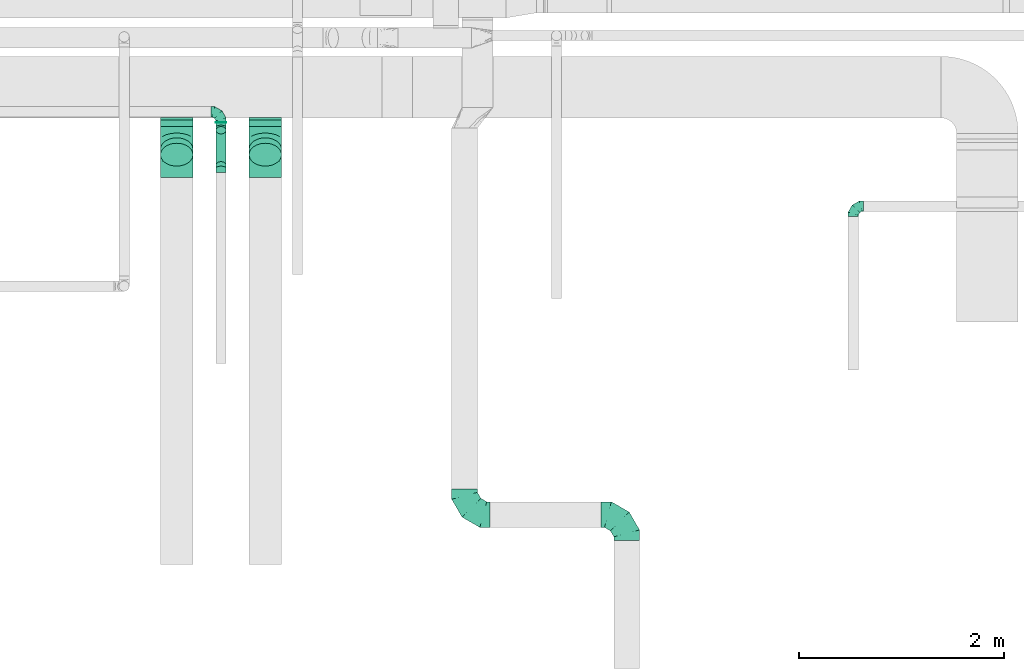
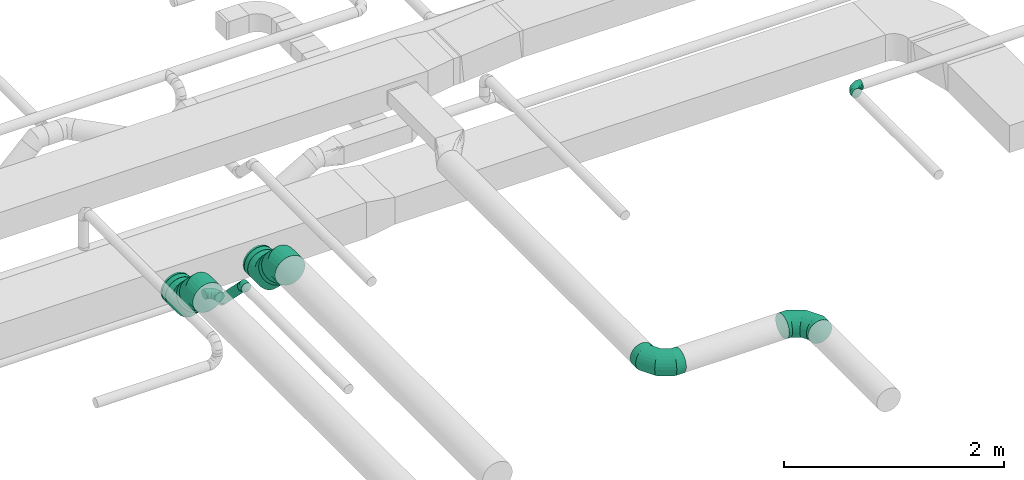
# One storey, part 37 of 60: 12 flow fittings, 6 flow segments.
"""IFC2X3 building model written with IfcOpenShell, lengths in millimetres."""

from ifc_helpers import new_model, entity, si_unit, converted_unit, derived_unit, direction, frame, origin, origin_2d_with_axis, place, context, subcontext, project, spatial, circle, extrude, faceted_brep, source, transform, mapped, material, type_object, type_shapes, element, save


model = new_model("IFC2X3")

# Units and contexts
model_context = context("Model", 3, precision=0.01, world=origin(), true_north=direction((6.12303176911189e-17, 1.0)))
body_context = subcontext(model_context, "Body", "Model", "MODEL_VIEW")
ifc_project = project(units=[si_unit("LENGTHUNIT", "METRE", prefix="MILLI"), si_unit("AREAUNIT", "SQUARE_METRE"), si_unit("VOLUMEUNIT", "CUBIC_METRE"), converted_unit("PLANEANGLEUNIT", "DEGREE", entity("IfcRatioMeasure", 0.0174532925199433), si_unit("PLANEANGLEUNIT", "RADIAN"), dimensions=[0, 0, 0, 0, 0, 0, 0]), si_unit("MASSUNIT", "GRAM", prefix="KILO"), derived_unit("MASSDENSITYUNIT", [(si_unit("MASSUNIT", "GRAM", prefix="KILO"), 1), (si_unit("LENGTHUNIT", "METRE"), -3)]), derived_unit("MOMENTOFINERTIAUNIT", [(si_unit("LENGTHUNIT", "METRE"), 4)]), si_unit("TIMEUNIT", "SECOND"), si_unit("FREQUENCYUNIT", "HERTZ"), si_unit("THERMODYNAMICTEMPERATUREUNIT", "DEGREE_CELSIUS"), derived_unit("THERMALTRANSMITTANCEUNIT", [(si_unit("MASSUNIT", "GRAM", prefix="KILO"), 1), (si_unit("THERMODYNAMICTEMPERATUREUNIT", "KELVIN"), -1), (si_unit("TIMEUNIT", "SECOND"), -3)]), derived_unit("VOLUMETRICFLOWRATEUNIT", [(si_unit("LENGTHUNIT", "METRE"), 3), (si_unit("TIMEUNIT", "SECOND"), -1)]), derived_unit("MASSFLOWRATEUNIT", [(si_unit("MASSUNIT", "GRAM", prefix="KILO"), 1), (si_unit("TIMEUNIT", "SECOND"), -1)]), derived_unit("ROTATIONALFREQUENCYUNIT", [(si_unit("TIMEUNIT", "SECOND"), -1)]), si_unit("ELECTRICCURRENTUNIT", "AMPERE"), si_unit("ELECTRICVOLTAGEUNIT", "VOLT"), si_unit("POWERUNIT", "WATT"), si_unit("FORCEUNIT", "NEWTON", prefix="KILO"), si_unit("ILLUMINANCEUNIT", "LUX"), si_unit("LUMINOUSFLUXUNIT", "LUMEN"), si_unit("LUMINOUSINTENSITYUNIT", "CANDELA"), derived_unit("USERDEFINED", [(si_unit("MASSUNIT", "GRAM", prefix="KILO"), -1), (si_unit("LENGTHUNIT", "METRE"), -2), (si_unit("TIMEUNIT", "SECOND"), 3), (si_unit("LUMINOUSFLUXUNIT", "LUMEN"), 1)]), derived_unit("LINEARVELOCITYUNIT", [(si_unit("LENGTHUNIT", "METRE"), 1), (si_unit("TIMEUNIT", "SECOND"), -1)]), si_unit("PRESSUREUNIT", "PASCAL"), derived_unit("USERDEFINED", [(si_unit("LENGTHUNIT", "METRE"), -2), (si_unit("MASSUNIT", "GRAM", prefix="KILO"), 1), (si_unit("TIMEUNIT", "SECOND"), -2)]), derived_unit("LINEARFORCEUNIT", [(si_unit("MASSUNIT", "GRAM", prefix="KILO"), 1), (si_unit("LENGTHUNIT", "METRE"), 1), (si_unit("TIMEUNIT", "SECOND"), -2), (si_unit("LENGTHUNIT", "METRE"), -1)]), derived_unit("PLANARFORCEUNIT", [(si_unit("MASSUNIT", "GRAM", prefix="KILO"), 1), (si_unit("LENGTHUNIT", "METRE"), 1), (si_unit("TIMEUNIT", "SECOND"), -2), (si_unit("LENGTHUNIT", "METRE"), -2)])], contexts=[model_context])

# Site, building, storey
site_placement = place(None, origin())
site = spatial("IfcSite", under=ifc_project, at=site_placement, CompositionType="ELEMENT")
building_placement = place(site_placement, origin())
building = spatial("IfcBuilding", under=site, at=building_placement, CompositionType="ELEMENT")
storey_placement = place(building_placement, frame((0.0, 0.0, 19800.0)))
storey = spatial("IfcBuildingStorey", under=building, at=storey_placement, CompositionType="ELEMENT", Elevation=19800.0)

# Flow segments
duct_segment_type = type_object("IfcDuctSegmentType", PredefinedType="NOTDEFINED")
flow_segment_1_placement = place(storey_placement, frame((57918.81, 8040.52, 2748.4)))
element("IfcFlowSegment", 1, at=flow_segment_1_placement, inside=storey, type_object=duct_segment_type, context=body_context, shape_type="SweptSolid", body=[
    extrude(circle(Radius=50.0, at=origin_2d_with_axis()), frame((51.6, 0.0, 51.6), z_axis=(0.0, 1.0, 0.0), x_axis=(-1.0, 0.0, 0.0)), (0.0, 0.0, 1.0), 8.5786437627044),
])
flow_segment_2_placement = place(storey_placement, frame((57918.81, 7591.43, 2792.34)))
element("IfcFlowSegment", 2, at=flow_segment_2_placement, inside=storey, type_object=duct_segment_type, context=body_context, shape_type="SweptSolid", body=[
    extrude(circle(Radius=50.0, at=origin_2d_with_axis()), frame((51.6, 378.37, 36.95), z_axis=(0.0, -0.707106781186546, 0.707106781186549), x_axis=(-1.0, 0.0, 0.0)), (0.0, 0.0, 1.0), 482.84271247463),
])
flow_segment_3_placement = place(storey_placement, frame((58242.69, 7618.75, 3011.8)))
element("IfcFlowSegment", 3, at=flow_segment_3_placement, inside=storey, type_object=duct_segment_type, context=body_context, shape_type="SweptSolid", body=[
    extrude(circle(Radius=157.5, at=origin_2d_with_axis()), frame((159.1, 165.94, 112.96), z_axis=(0.0, -0.707106781186428, 0.707106781186667), x_axis=(1.0, 0.0, 0.0)), (0.0, 0.0, 1.0), 74.9211767686856),
])
flow_segment_4_placement = place(storey_placement, frame((58242.69, 8007.48, 2873.36)))
element("IfcFlowSegment", 4, at=flow_segment_4_placement, inside=storey, type_object=duct_segment_type, context=body_context, shape_type="SweptSolid", body=[
    extrude(circle(Radius=157.5, at=origin_2d_with_axis()), frame((159.1, 0.0, 159.1), z_axis=(0.0, 1.0, 0.0), x_axis=(1.0, 0.0, 0.0)), (0.0, 0.0, 1.0), 61.9743878930634),
])
flow_segment_5_placement = place(storey_placement, frame((57379.82, 7618.75, 3011.8)))
element("IfcFlowSegment", 5, at=flow_segment_5_placement, inside=storey, type_object=duct_segment_type, context=body_context, shape_type="SweptSolid", body=[
    extrude(circle(Radius=157.5, at=origin_2d_with_axis()), frame((159.1, 112.96, 165.94), z_axis=(0.0, 0.707106781186554, -0.707106781186541), x_axis=(1.0, 0.0, 0.0)), (0.0, 0.0, 1.0), 74.9211767686642),
])
flow_segment_6_placement = place(storey_placement, frame((57379.82, 8007.48, 2873.36)))
element("IfcFlowSegment", 6, at=flow_segment_6_placement, inside=storey, type_object=duct_segment_type, context=body_context, shape_type="SweptSolid", body=[
    extrude(circle(Radius=157.5, at=origin_2d_with_axis()), frame((159.1, 0.0, 159.1), z_axis=(0.0, 1.0, 0.0), x_axis=(1.0, 0.0, 0.0)), (0.0, 0.0, 1.0), 61.97438789311),
])

# Flow fittings
ifc_material = material()
duct_fitting_type_1 = type_object("IfcDuctFittingType", PredefinedType="NOTDEFINED", material=ifc_material)
shared_shape_1 = source(origin(), body_context, "Body", "Brep", [
    faceted_brep([(-100.0, 0.0, -50.0), (-100.0, -12.94, -48.3), (-100.0, -25.0, -43.3), (-100.0, -35.36, -35.36), (-100.0, -43.3, -25.0), (-100.0, -48.3, -12.94), (-100.0, -50.0, 0.0), (-100.0, -48.3, 12.94), (-100.0, -43.3, 25.0), (-100.0, -35.36, 35.36), (-100.0, -25.0, 43.3), (-100.0, -12.94, 48.3), (-100.0, 0.0, 50.0), (-100.0, 12.94, 48.3), (-100.0, 25.0, 43.3), (-100.0, 35.36, 35.36), (-100.0, 43.3, 25.0), (-100.0, 48.3, 12.94), (-100.0, 50.0, 0.0), (-100.0, 48.3, -12.94), (-100.0, 43.3, -25.0), (-100.0, 35.36, -35.36), (-100.0, 25.0, -43.3), (-100.0, 12.94, -48.3), (-76.67, 12.94, 48.3), (-79.9, 25.0, 43.3), (-73.21, 0.0, 50.0), (-82.68, 35.36, 35.36), (-86.15, 48.3, 12.94), (-86.6, 50.0, 0.0), (-84.81, 43.3, 25.0), (-84.81, 43.3, -25.0), (-82.68, 35.36, -35.36), (-86.15, 48.3, -12.94), (-76.67, 12.94, -48.3), (-73.21, 0.0, -50.0), (-79.9, 25.0, -43.3), (-69.74, -12.94, -48.3), (-66.51, -25.0, -43.3), (-63.73, -35.36, -35.36), (-61.6, -43.3, -25.0), (-60.26, -48.3, -12.94), (-59.81, -50.0, 0.0), (-60.26, -48.3, 12.94), (-61.6, -43.3, 25.0), (-63.73, -35.36, 35.36), (-66.51, -25.0, 43.3), (-69.74, -12.94, 48.3), (-36.27, 36.27, 48.3), (-45.1, 45.1, 43.3), (-26.79, 26.79, 50.0), (-52.68, 52.68, 35.36), (-58.49, 58.49, 25.0), (-62.15, 62.15, 12.94), (-63.4, 63.4, 0.0), (-62.15, 62.15, -12.94), (-58.49, 58.49, -25.0), (-52.68, 52.68, -35.36), (-36.27, 36.27, -48.3), (-26.79, 26.79, -50.0), (-45.1, 45.1, -43.3), (-17.32, 17.32, -48.3), (-8.49, 8.49, -43.3), (-0.91, 0.91, -35.36), (4.9, -4.9, -25.0), (8.56, -8.56, -12.94), (9.81, -9.81, 0.0), (8.56, -8.56, 12.94), (4.9, -4.9, 25.0), (-0.91, 0.91, 35.36), (-8.49, 8.49, 43.3), (-17.32, 17.32, 48.3), (-12.94, 76.67, 48.3), (-25.0, 79.9, 43.3), (0.0, 73.21, 50.0), (-35.36, 82.68, 35.36), (-43.3, 84.81, 25.0), (-48.3, 86.15, 12.94), (-50.0, 86.6, 0.0), (-48.3, 86.15, -12.94), (-43.3, 84.81, -25.0), (-35.36, 82.68, -35.36), (-12.94, 76.67, -48.3), (0.0, 73.21, -50.0), (-25.0, 79.9, -43.3), (12.94, 69.74, -48.3), (25.0, 66.51, -43.3), (35.36, 63.73, -35.36), (43.3, 61.6, -25.0), (48.3, 60.26, -12.94), (50.0, 59.81, 0.0), (48.3, 60.26, 12.94), (43.3, 61.6, 25.0), (35.36, 63.73, 35.36), (25.0, 66.51, 43.3), (12.94, 69.74, 48.3), (-12.94, 100.0, -48.3), (-25.0, 100.0, -43.3), (-35.36, 100.0, -35.36), (-43.3, 100.0, -25.0), (-48.3, 100.0, -12.94), (-50.0, 100.0, 0.0), (-48.3, 100.0, 12.94), (-43.3, 100.0, 25.0), (-35.36, 100.0, 35.36), (-25.0, 100.0, 43.3), (-12.94, 100.0, 48.3), (0.0, 100.0, 50.0), (12.94, 100.0, 48.3), (25.0, 100.0, 43.3), (35.36, 100.0, 35.36), (43.3, 100.0, 25.0), (48.3, 100.0, 12.94), (50.0, 100.0, 0.0), (48.3, 100.0, -12.94), (43.3, 100.0, -25.0), (35.36, 100.0, -35.36), (25.0, 100.0, -43.3), (12.94, 100.0, -48.3), (0.0, 100.0, -50.0)], [[[0, 1, 2, 3, 4, 5, 6, 7, 8, 9, 10, 11, 12, 13, 14, 15, 16, 17, 18, 19, 20, 21, 22, 23]], [[24, 25, 14, 13]], [[26, 24, 13, 12]], [[14, 25, 27, 15]], [[28, 29, 18, 17]], [[30, 28, 17, 16]], [[15, 27, 30, 16]], [[20, 31, 32, 21]], [[33, 31, 20, 19]], [[18, 29, 33, 19]], [[34, 35, 0, 23]], [[36, 34, 23, 22]], [[32, 36, 22, 21]], [[2, 1, 37, 38]], [[3, 2, 38, 39]], [[0, 35, 37, 1]], [[5, 4, 40, 41]], [[6, 5, 41, 42]], [[3, 39, 40, 4]], [[6, 42, 43, 7]], [[7, 43, 44, 8]], [[8, 44, 45, 9]], [[10, 46, 47, 11]], [[11, 47, 26, 12]], [[10, 9, 45, 46]], [[48, 49, 25, 24]], [[50, 48, 24, 26]], [[27, 25, 49, 51]], [[52, 53, 28, 30]], [[51, 52, 30, 27]], [[29, 28, 53, 54]], [[55, 56, 31, 33]], [[54, 55, 33, 29]], [[57, 32, 31, 56]], [[58, 59, 35, 34]], [[60, 58, 34, 36]], [[57, 60, 36, 32]], [[37, 35, 59, 61]], [[38, 37, 61, 62]], [[39, 38, 62, 63]], [[41, 40, 64, 65]], [[42, 41, 65, 66]], [[63, 64, 40, 39]], [[43, 42, 66, 67]], [[44, 43, 67, 68]], [[68, 69, 45, 44]], [[46, 45, 69, 70]], [[47, 46, 70, 71]], [[26, 47, 71, 50]], [[72, 73, 49, 48]], [[74, 72, 48, 50]], [[51, 49, 73, 75]], [[76, 77, 53, 52]], [[75, 76, 52, 51]], [[54, 53, 77, 78]], [[79, 80, 56, 55]], [[78, 79, 55, 54]], [[81, 57, 56, 80]], [[82, 83, 59, 58]], [[84, 82, 58, 60]], [[81, 84, 60, 57]], [[61, 59, 83, 85]], [[62, 61, 85, 86]], [[63, 62, 86, 87]], [[65, 64, 88, 89]], [[66, 65, 89, 90]], [[87, 88, 64, 63]], [[67, 66, 90, 91]], [[68, 67, 91, 92]], [[92, 93, 69, 68]], [[70, 69, 93, 94]], [[71, 70, 94, 95]], [[50, 71, 95, 74]], [[96, 97, 98, 99, 100, 101, 102, 103, 104, 105, 106, 107, 108, 109, 110, 111, 112, 113, 114, 115, 116, 117, 118, 119]], [[72, 74, 107, 106]], [[73, 72, 106, 105]], [[75, 73, 105, 104]], [[77, 76, 103, 102]], [[78, 77, 102, 101]], [[75, 104, 103, 76]], [[78, 101, 100, 79]], [[79, 100, 99, 80]], [[80, 99, 98, 81]], [[96, 119, 83, 82]], [[97, 96, 82, 84]], [[84, 81, 98, 97]], [[83, 119, 118, 85]], [[85, 118, 117, 86]], [[86, 117, 116, 87]], [[88, 115, 114, 89]], [[89, 114, 113, 90]], [[87, 116, 115, 88]], [[91, 90, 113, 112]], [[92, 91, 112, 111]], [[93, 92, 111, 110]], [[95, 94, 109, 108]], [[74, 95, 108, 107]], [[110, 109, 94, 93]]]),
])
type_shapes(duct_fitting_type_1, [shared_shape_1])
for number, where, z_axis, x_axis in (
    (7, (57970.41, 8149.09, 2800.0), (0.0, 0.0, 1.0), (0.0, 1.0, 0.0)),
    (8, (64130.0, 7230.17, 3460.0), (0.0, 0.0, 1.0), (-1.0, 0.0, 0.0)),
):
    element("IfcFlowFitting", number, at=place(storey_placement, frame(where, z_axis=z_axis, x_axis=x_axis)), inside=storey, type_object=duct_fitting_type_1, material=ifc_material, context=body_context, shape_type="MappedRepresentation", body=[
        mapped(shared_shape_1, transform((0.0, 0.0, 0.0), scale=1.0)),
    ])
duct_fitting_type_2 = type_object("IfcDuctFittingType", PredefinedType="NOTDEFINED", material=ifc_material)
shared_shape_2 = source(origin(), body_context, "Body", "Brep", [
    faceted_brep([(-250.0, 0.0, -125.0), (-250.0, -32.35, -120.74), (-250.0, -62.5, -108.25), (-250.0, -88.39, -88.39), (-250.0, -108.25, -62.5), (-250.0, -120.74, -32.35), (-250.0, -125.0, 0.0), (-250.0, -120.74, 32.35), (-250.0, -108.25, 62.5), (-250.0, -88.39, 88.39), (-250.0, -62.5, 108.25), (-250.0, -32.35, 120.74), (-250.0, 0.0, 125.0), (-250.0, 32.35, 120.74), (-250.0, 62.5, 108.25), (-250.0, 88.39, 88.39), (-250.0, 108.25, 62.5), (-250.0, 120.74, 32.35), (-250.0, 125.0, 0.0), (-250.0, 120.74, -32.35), (-250.0, 108.25, -62.5), (-250.0, 88.39, -88.39), (-250.0, 62.5, -108.25), (-250.0, 32.35, -120.74), (-191.68, 32.35, 120.74), (-199.76, 62.5, 108.25), (-183.01, 0.0, 125.0), (-206.7, 88.39, 88.39), (-215.37, 120.74, 32.35), (-216.51, 125.0, 0.0), (-212.02, 108.25, 62.5), (-212.02, 108.25, -62.5), (-206.7, 88.39, -88.39), (-215.37, 120.74, -32.35), (-191.68, 32.35, -120.74), (-183.01, 0.0, -125.0), (-199.76, 62.5, -108.25), (-174.34, -32.35, -120.74), (-166.27, -62.5, -108.25), (-159.33, -88.39, -88.39), (-154.01, -108.25, -62.5), (-150.66, -120.74, -32.35), (-149.52, -125.0, 0.0), (-150.66, -120.74, 32.35), (-154.01, -108.25, 62.5), (-159.33, -88.39, 88.39), (-166.27, -62.5, 108.25), (-174.34, -32.35, 120.74), (-90.67, 90.67, 120.74), (-112.74, 112.74, 108.25), (-66.99, 66.99, 125.0), (-131.69, 131.69, 88.39), (-146.23, 146.23, 62.5), (-155.38, 155.38, 32.35), (-158.49, 158.49, 0.0), (-155.38, 155.38, -32.35), (-146.23, 146.23, -62.5), (-131.69, 131.69, -88.39), (-90.67, 90.67, -120.74), (-66.99, 66.99, -125.0), (-112.74, 112.74, -108.25), (-43.3, 43.3, -120.74), (-21.23, 21.23, -108.25), (-2.28, 2.28, -88.39), (12.26, -12.26, -62.5), (21.4, -21.4, -32.35), (24.52, -24.52, 0.0), (21.4, -21.4, 32.35), (12.26, -12.26, 62.5), (-2.28, 2.28, 88.39), (-21.23, 21.23, 108.25), (-43.3, 43.3, 120.74), (-32.35, 191.68, 120.74), (-62.5, 199.76, 108.25), (0.0, 183.01, 125.0), (-88.39, 206.7, 88.39), (-108.25, 212.02, 62.5), (-120.74, 215.37, 32.35), (-125.0, 216.51, 0.0), (-120.74, 215.37, -32.35), (-108.25, 212.02, -62.5), (-88.39, 206.7, -88.39), (-32.35, 191.68, -120.74), (0.0, 183.01, -125.0), (-62.5, 199.76, -108.25), (32.35, 174.34, -120.74), (62.5, 166.27, -108.25), (88.39, 159.33, -88.39), (108.25, 154.01, -62.5), (120.74, 150.66, -32.35), (125.0, 149.52, 0.0), (120.74, 150.66, 32.35), (108.25, 154.01, 62.5), (88.39, 159.33, 88.39), (62.5, 166.27, 108.25), (32.35, 174.34, 120.74), (-32.35, 250.0, -120.74), (-62.5, 250.0, -108.25), (-88.39, 250.0, -88.39), (-108.25, 250.0, -62.5), (-120.74, 250.0, -32.35), (-125.0, 250.0, 0.0), (-120.74, 250.0, 32.35), (-108.25, 250.0, 62.5), (-88.39, 250.0, 88.39), (-62.5, 250.0, 108.25), (-32.35, 250.0, 120.74), (0.0, 250.0, 125.0), (32.35, 250.0, 120.74), (62.5, 250.0, 108.25), (88.39, 250.0, 88.39), (108.25, 250.0, 62.5), (120.74, 250.0, 32.35), (125.0, 250.0, 0.0), (120.74, 250.0, -32.35), (108.25, 250.0, -62.5), (88.39, 250.0, -88.39), (62.5, 250.0, -108.25), (32.35, 250.0, -120.74), (0.0, 250.0, -125.0)], [[[0, 1, 2, 3, 4, 5, 6, 7, 8, 9, 10, 11, 12, 13, 14, 15, 16, 17, 18, 19, 20, 21, 22, 23]], [[24, 25, 14, 13]], [[26, 24, 13, 12]], [[14, 25, 27, 15]], [[28, 29, 18, 17]], [[30, 28, 17, 16]], [[15, 27, 30, 16]], [[20, 31, 32, 21]], [[33, 31, 20, 19]], [[18, 29, 33, 19]], [[34, 35, 0, 23]], [[36, 34, 23, 22]], [[21, 32, 36, 22]], [[1, 0, 35, 37]], [[2, 1, 37, 38]], [[38, 39, 3, 2]], [[5, 4, 40, 41]], [[6, 5, 41, 42]], [[39, 40, 4, 3]], [[6, 42, 43, 7]], [[7, 43, 44, 8]], [[8, 44, 45, 9]], [[9, 45, 46, 10]], [[10, 46, 47, 11]], [[26, 12, 11, 47]], [[48, 49, 25, 24]], [[50, 48, 24, 26]], [[27, 25, 49, 51]], [[52, 53, 28, 30]], [[51, 52, 30, 27]], [[29, 28, 53, 54]], [[55, 56, 31, 33]], [[54, 55, 33, 29]], [[32, 31, 56, 57]], [[58, 59, 35, 34]], [[60, 58, 34, 36]], [[57, 60, 36, 32]], [[37, 35, 59, 61]], [[38, 37, 61, 62]], [[39, 38, 62, 63]], [[41, 40, 64, 65]], [[42, 41, 65, 66]], [[63, 64, 40, 39]], [[43, 42, 66, 67]], [[44, 43, 67, 68]], [[68, 69, 45, 44]], [[46, 45, 69, 70]], [[47, 46, 70, 71]], [[26, 47, 71, 50]], [[72, 73, 49, 48]], [[74, 72, 48, 50]], [[51, 49, 73, 75]], [[76, 77, 53, 52]], [[75, 76, 52, 51]], [[54, 53, 77, 78]], [[79, 80, 56, 55]], [[78, 79, 55, 54]], [[57, 56, 80, 81]], [[82, 83, 59, 58]], [[84, 82, 58, 60]], [[81, 84, 60, 57]], [[61, 59, 83, 85]], [[62, 61, 85, 86]], [[63, 62, 86, 87]], [[65, 64, 88, 89]], [[66, 65, 89, 90]], [[87, 88, 64, 63]], [[67, 66, 90, 91]], [[68, 67, 91, 92]], [[92, 93, 69, 68]], [[70, 69, 93, 94]], [[71, 70, 94, 95]], [[50, 71, 95, 74]], [[96, 97, 98, 99, 100, 101, 102, 103, 104, 105, 106, 107, 108, 109, 110, 111, 112, 113, 114, 115, 116, 117, 118, 119]], [[72, 74, 107, 106]], [[73, 72, 106, 105]], [[75, 73, 105, 104]], [[77, 76, 103, 102]], [[78, 77, 102, 101]], [[75, 104, 103, 76]], [[78, 101, 100, 79]], [[79, 100, 99, 80]], [[80, 99, 98, 81]], [[84, 97, 96, 82]], [[82, 96, 119, 83]], [[84, 81, 98, 97]], [[83, 119, 118, 85]], [[85, 118, 117, 86]], [[116, 87, 86, 117]], [[88, 115, 114, 89]], [[89, 114, 113, 90]], [[115, 88, 87, 116]], [[91, 90, 113, 112]], [[92, 91, 112, 111]], [[111, 110, 93, 92]], [[95, 94, 109, 108]], [[74, 95, 108, 107]], [[110, 109, 94, 93]]]),
])
type_shapes(duct_fitting_type_2, [shared_shape_2])
for number, where, z_axis, x_axis in (
    (9, (60343.37, 4224.68, 3500.0), (0.0, 0.0, 1.0), (0.0, -1.0, 0.0)),
    (10, (61923.37, 4224.68, 3500.0), (0.0, 0.0, 1.0), (0.0, 1.0, 0.0)),
):
    element("IfcFlowFitting", number, at=place(storey_placement, frame(where, z_axis=z_axis, x_axis=x_axis)), inside=storey, type_object=duct_fitting_type_2, material=ifc_material, context=body_context, shape_type="MappedRepresentation", body=[
        mapped(shared_shape_2, transform((0.0, 0.0, 0.0), scale=1.0)),
    ])
duct_fitting_type_3 = type_object("IfcDuctFittingType", PredefinedType="NOTDEFINED", material=ifc_material)
shared_shape_3 = source(origin(), body_context, "Body", "Brep", [
    faceted_brep([(-41.42, 0.0, -50.0), (-41.42, -12.94, -48.3), (-41.42, -25.0, -43.3), (-41.42, -35.36, -35.36), (-41.42, -43.3, -25.0), (-41.42, -48.3, -12.94), (-41.42, -50.0, 0.0), (-41.42, -48.3, 12.94), (-41.42, -43.3, 25.0), (-41.42, -35.36, 35.36), (-41.42, -25.0, 43.3), (-41.42, -12.94, 48.3), (-41.42, 0.0, 50.0), (-41.42, 12.94, 48.3), (-41.42, 25.0, 43.3), (-41.42, 35.36, 35.36), (-41.42, 43.3, 25.0), (-41.42, 48.3, 12.94), (-41.42, 50.0, 0.0), (-41.42, 48.3, -12.94), (-41.42, 43.3, -25.0), (-41.42, 35.36, -35.36), (-41.42, 25.0, -43.3), (-41.42, 12.94, -48.3), (-5.36, 12.94, 48.3), (-10.36, 25.0, 43.3), (0.0, 0.0, 50.0), (-14.64, 35.36, 35.36), (-20.0, 48.3, 12.94), (-20.71, 50.0, 0.0), (-17.94, 43.3, 25.0), (-17.94, 43.3, -25.0), (-14.64, 35.36, -35.36), (-20.0, 48.3, -12.94), (-5.36, 12.94, -48.3), (0.0, 0.0, -50.0), (-10.36, 25.0, -43.3), (5.36, -12.94, -48.3), (10.36, -25.0, -43.3), (14.64, -35.36, -35.36), (17.94, -43.3, -25.0), (20.0, -48.3, -12.94), (20.71, -50.0, 0.0), (20.0, -48.3, 12.94), (17.94, -43.3, 25.0), (14.64, -35.36, 35.36), (10.36, -25.0, 43.3), (5.36, -12.94, 48.3), (29.29, 29.29, 50.0), (20.14, 38.44, 48.3), (11.61, 46.97, 43.3), (4.29, 54.29, 35.36), (-1.33, 59.91, 25.0), (-4.86, 63.44, 12.94), (-6.07, 64.64, 0.0), (-4.86, 63.44, -12.94), (-1.33, 59.91, -25.0), (4.29, 54.29, -35.36), (11.61, 46.97, -43.3), (20.14, 38.44, -48.3), (29.29, 29.29, -50.0), (38.44, 20.14, -48.3), (46.97, 11.61, -43.3), (54.29, 4.29, -35.36), (59.91, -1.33, -25.0), (63.44, -4.86, -12.94), (64.64, -6.07, 0.0), (63.44, -4.86, 12.94), (59.91, -1.33, 25.0), (54.29, 4.29, 35.36), (46.97, 11.61, 43.3), (38.44, 20.14, 48.3)], [[[0, 1, 2, 3, 4, 5, 6, 7, 8, 9, 10, 11, 12, 13, 14, 15, 16, 17, 18, 19, 20, 21, 22, 23]], [[24, 25, 14, 13]], [[26, 24, 13, 12]], [[14, 25, 27, 15]], [[28, 29, 18, 17]], [[30, 28, 17, 16]], [[16, 15, 27, 30]], [[20, 31, 32, 21]], [[33, 31, 20, 19]], [[18, 29, 33, 19]], [[34, 35, 0, 23]], [[36, 34, 23, 22]], [[32, 36, 22, 21]], [[1, 0, 35, 37]], [[2, 1, 37, 38]], [[38, 39, 3, 2]], [[5, 4, 40, 41]], [[6, 5, 41, 42]], [[39, 40, 4, 3]], [[6, 42, 43, 7]], [[7, 43, 44, 8]], [[8, 44, 45, 9]], [[9, 45, 46, 10]], [[10, 46, 47, 11]], [[26, 12, 11, 47]], [[24, 26, 48, 49]], [[25, 24, 49, 50]], [[27, 25, 50, 51]], [[28, 30, 52, 53]], [[29, 28, 53, 54]], [[27, 51, 52, 30]], [[29, 54, 55, 33]], [[33, 55, 56, 31]], [[31, 56, 57, 32]], [[36, 58, 59, 34]], [[34, 59, 60, 35]], [[36, 32, 57, 58]], [[61, 62, 38, 37]], [[60, 61, 37, 35]], [[63, 39, 38, 62]], [[40, 64, 65, 41]], [[41, 65, 66, 42]], [[64, 40, 39, 63]], [[43, 42, 66, 67]], [[44, 43, 67, 68]], [[68, 69, 45, 44]], [[47, 46, 70, 71]], [[26, 47, 71, 48]], [[69, 70, 46, 45]], [[59, 58, 57, 56, 55, 54, 53, 52, 51, 50, 49, 48, 71, 70, 69, 68, 67, 66, 65, 64, 63, 62, 61, 60]]]),
])
type_shapes(duct_fitting_type_3, [shared_shape_3])
for number, where, z_axis, x_axis in (
    (11, (57970.41, 7999.09, 2800.0), (-1.0, 0.0, 0.0), (0.0, -1.0, 0.0)),
    (12, (57970.41, 7599.09, 3200.0), (1.0, 0.0, 0.0), (0.0, -0.707106781186532, 0.707106781186563)),
):
    element("IfcFlowFitting", number, at=place(storey_placement, frame(where, z_axis=z_axis, x_axis=x_axis)), inside=storey, type_object=duct_fitting_type_3, material=ifc_material, context=body_context, shape_type="MappedRepresentation", body=[
        mapped(shared_shape_3, transform((0.0, 0.0, 0.0), scale=1.0)),
    ])
duct_fitting_type_4 = type_object("IfcDuctFittingType", PredefinedType="NOTDEFINED", material=ifc_material)
shared_shape_4 = source(origin(), body_context, "Body", "Brep", [
    faceted_brep([(-130.48, 0.0, -157.5), (-130.48, -40.76, -152.13), (-130.48, -78.75, -136.4), (-130.48, -111.37, -111.37), (-130.48, -136.4, -78.75), (-130.48, -152.13, -40.76), (-130.48, -157.5, 0.0), (-130.48, -152.13, 40.76), (-130.48, -136.4, 78.75), (-130.48, -111.37, 111.37), (-130.48, -78.75, 136.4), (-130.48, -40.76, 152.13), (-130.48, 0.0, 157.5), (-130.48, 40.76, 152.13), (-130.48, 78.75, 136.4), (-130.48, 111.37, 111.37), (-130.48, 136.4, 78.75), (-130.48, 152.13, 40.76), (-130.48, 157.5, 0.0), (-130.48, 152.13, -40.76), (-130.48, 136.4, -78.75), (-130.48, 111.37, -111.37), (-130.48, 78.75, -136.4), (-130.48, 40.76, -152.13), (-16.89, 40.76, 152.13), (-32.62, 78.75, 136.4), (0.0, 0.0, 157.5), (-46.13, 111.37, 111.37), (-63.02, 152.13, 40.76), (-65.24, 157.5, 0.0), (-56.5, 136.4, 78.75), (-56.5, 136.4, -78.75), (-46.13, 111.37, -111.37), (-63.02, 152.13, -40.76), (-16.89, 40.76, -152.13), (0.0, 0.0, -157.5), (-32.62, 78.75, -136.4), (16.89, -40.76, -152.13), (32.62, -78.75, -136.4), (46.13, -111.37, -111.37), (56.5, -136.4, -78.75), (63.02, -152.13, -40.76), (65.24, -157.5, 0.0), (63.02, -152.13, 40.76), (56.5, -136.4, 78.75), (46.13, -111.37, 111.37), (32.62, -78.75, 136.4), (16.89, -40.76, 152.13), (92.26, 92.26, 157.5), (63.44, 121.09, 152.13), (36.58, 147.95, 136.4), (13.51, 171.01, 111.37), (-4.19, 188.71, 78.75), (-15.31, 199.84, 40.76), (-19.11, 203.63, 0.0), (-15.31, 199.84, -40.76), (-4.19, 188.71, -78.75), (13.51, 171.01, -111.37), (36.58, 147.95, -136.4), (63.44, 121.09, -152.13), (92.26, 92.26, -157.5), (121.09, 63.44, -152.13), (147.95, 36.58, -136.4), (171.01, 13.51, -111.37), (188.71, -4.19, -78.75), (199.84, -15.31, -40.76), (203.63, -19.11, 0.0), (199.84, -15.31, 40.76), (188.71, -4.19, 78.75), (171.01, 13.51, 111.37), (147.95, 36.58, 136.4), (121.09, 63.44, 152.13)], [[[0, 1, 2, 3, 4, 5, 6, 7, 8, 9, 10, 11, 12, 13, 14, 15, 16, 17, 18, 19, 20, 21, 22, 23]], [[24, 25, 14, 13]], [[26, 24, 13, 12]], [[14, 25, 27, 15]], [[28, 29, 18, 17]], [[30, 28, 17, 16]], [[15, 27, 30, 16]], [[20, 31, 32, 21]], [[33, 31, 20, 19]], [[18, 29, 33, 19]], [[34, 35, 0, 23]], [[36, 34, 23, 22]], [[32, 36, 22, 21]], [[1, 0, 35, 37]], [[2, 1, 37, 38]], [[38, 39, 3, 2]], [[5, 4, 40, 41]], [[6, 5, 41, 42]], [[39, 40, 4, 3]], [[6, 42, 43, 7]], [[7, 43, 44, 8]], [[8, 44, 45, 9]], [[9, 45, 46, 10]], [[10, 46, 47, 11]], [[26, 12, 11, 47]], [[24, 26, 48, 49]], [[25, 24, 49, 50]], [[27, 25, 50, 51]], [[28, 30, 52, 53]], [[29, 28, 53, 54]], [[51, 52, 30, 27]], [[55, 56, 31, 33]], [[54, 55, 33, 29]], [[57, 32, 31, 56]], [[36, 58, 59, 34]], [[34, 59, 60, 35]], [[58, 36, 32, 57]], [[35, 60, 61, 37]], [[37, 61, 62, 38]], [[63, 39, 38, 62]], [[40, 64, 65, 41]], [[41, 65, 66, 42]], [[64, 40, 39, 63]], [[43, 42, 66, 67]], [[44, 43, 67, 68]], [[68, 69, 45, 44]], [[47, 46, 70, 71]], [[26, 47, 71, 48]], [[69, 70, 46, 45]], [[54, 53, 52, 51, 50, 49, 48, 71, 70, 69, 68, 67, 66, 65, 64, 63, 62, 61, 60, 59, 58, 57, 56, 55]]]),
])
type_shapes(duct_fitting_type_4, [shared_shape_4])
for number, where, z_axis, x_axis in (
    (13, (58401.79, 7639.45, 3270.0), (-1.0, 0.0, 0.0), (0.0, 1.0, 0.0)),
    (14, (58401.79, 7876.95, 3032.5), (1.0, 0.0, 0.0), (0.0, 0.707106781186432, -0.707106781186663)),
    (15, (57538.92, 7639.45, 3270.0), (-1.0, 0.0, 0.0), (0.0, 1.0, 0.0)),
    (16, (57538.92, 7876.95, 3032.5), (1.0, 0.0, 0.0), (0.0, 0.707106781186425, -0.70710678118667)),
):
    element("IfcFlowFitting", number, at=place(storey_placement, frame(where, z_axis=z_axis, x_axis=x_axis)), inside=storey, type_object=duct_fitting_type_4, material=ifc_material, context=body_context, shape_type="MappedRepresentation", body=[
        mapped(shared_shape_4, transform((0.0, 0.0, 0.0), scale=1.0)),
    ])
duct_fitting_type_5 = type_object("IfcDuctFittingType", PredefinedType="NOTDEFINED", material=ifc_material)
shared_shape_5 = source(origin(), body_context, "Body", "Brep", [
    faceted_brep([(20.0, 0.0, -157.5), (20.0, 40.76, -152.13), (20.0, 78.75, -136.4), (20.0, 111.37, -111.37), (20.0, 136.4, -78.75), (20.0, 152.13, -40.76), (20.0, 157.5, 0.0), (20.0, 152.13, 40.76), (20.0, 136.4, 78.75), (20.0, 111.37, 111.37), (20.0, 78.75, 136.4), (20.0, 40.76, 152.13), (20.0, 0.0, 157.5), (20.0, -40.76, 152.13), (20.0, -78.75, 136.4), (20.0, -111.37, 111.37), (20.0, -136.4, 78.75), (20.0, -152.13, 40.76), (20.0, -157.5, 0.0), (20.0, -152.13, -40.76), (20.0, -136.4, -78.75), (20.0, -111.37, -111.37), (20.0, -78.75, -136.4), (20.0, -40.76, -152.13), (0.0, 0.0, 157.5), (-6.1, 0.0, 157.5), (-6.1, -40.76, 152.13), (0.0, -40.76, 152.13), (-6.1, -78.75, 136.4), (0.0, -78.75, 136.4), (0.0, -111.37, 111.37), (-6.1, -111.37, 111.37), (0.0, -136.4, 78.75), (-6.1, -136.4, 78.75), (-6.1, -152.13, 40.76), (0.0, -152.13, 40.76), (-6.1, -157.5, 0.0), (0.0, -157.5, 0.0), (-6.1, -152.13, -40.76), (0.0, -152.13, -40.76), (-6.1, -136.4, -78.75), (0.0, -136.4, -78.75), (0.0, -111.37, -111.37), (-6.1, -111.37, -111.37), (0.0, 0.0, -157.5), (0.0, -40.76, -152.13), (-6.1, -40.76, -152.13), (-6.1, 0.0, -157.5), (0.0, -78.75, -136.4), (-6.1, -78.75, -136.4), (-6.1, 40.76, -152.13), (0.0, 40.76, -152.13), (-6.1, 78.75, -136.4), (0.0, 78.75, -136.4), (0.0, 111.37, -111.37), (-6.1, 111.37, -111.37), (0.0, 136.4, -78.75), (-6.1, 136.4, -78.75), (-6.1, 152.13, -40.76), (0.0, 152.13, -40.76), (-6.1, 157.5, 0.0), (0.0, 157.5, 0.0), (-6.1, 152.13, 40.76), (0.0, 152.13, 40.76), (-6.1, 136.4, 78.75), (0.0, 136.4, 78.75), (0.0, 111.37, 111.37), (-6.1, 111.37, 111.37), (0.0, 78.75, 136.4), (-6.1, 78.75, 136.4), (-6.1, 40.76, 152.13), (0.0, 40.76, 152.13)], [[[0, 1, 2, 3, 4, 5, 6, 7, 8, 9, 10, 11, 12, 13, 14, 15, 16, 17, 18, 19, 20, 21, 22, 23]], [[13, 12, 24, 25, 26, 27]], [[14, 13, 27, 26, 28, 29]], [[30, 15, 14, 29, 28, 31]], [[17, 16, 32, 33, 34, 35]], [[18, 17, 35, 34, 36, 37]], [[32, 16, 15, 30, 31, 33]], [[19, 18, 37, 36, 38, 39]], [[20, 19, 39, 38, 40, 41]], [[42, 21, 20, 41, 40, 43]], [[44, 0, 23, 45, 46, 47]], [[48, 49, 46, 45, 23, 22]], [[22, 21, 42, 43, 49, 48]], [[1, 0, 44, 47, 50, 51]], [[2, 1, 51, 50, 52, 53]], [[54, 3, 2, 53, 52, 55]], [[5, 4, 56, 57, 58, 59]], [[6, 5, 59, 58, 60, 61]], [[56, 4, 3, 54, 55, 57]], [[7, 6, 61, 60, 62, 63]], [[8, 7, 63, 62, 64, 65]], [[66, 9, 8, 65, 64, 67]], [[11, 10, 68, 69, 70, 71]], [[12, 11, 71, 70, 25, 24]], [[68, 10, 9, 66, 67, 69]], [[46, 49, 43, 40, 38, 36, 34, 33, 31, 28, 26, 25, 70, 69, 67, 64, 62, 60, 58, 57, 55, 52, 50, 47]]]),
])
type_shapes(duct_fitting_type_5, [shared_shape_5])
for number, where, z_axis, x_axis in (
    (17, (58401.79, 8089.45, 3032.45), (0.0, 0.0, -1.0), (0.0, -1.0, 0.0)),
    (18, (57538.92, 8089.45, 3032.45), (0.0, 0.0, -1.0), (0.0, -1.0, 0.0)),
):
    element("IfcFlowFitting", number, at=place(storey_placement, frame(where, z_axis=z_axis, x_axis=x_axis)), inside=storey, type_object=duct_fitting_type_5, material=ifc_material, context=body_context, shape_type="MappedRepresentation", body=[
        mapped(shared_shape_5, transform((0.0, 0.0, 0.0), scale=1.0)),
    ])

save(model, "model.ifc")
